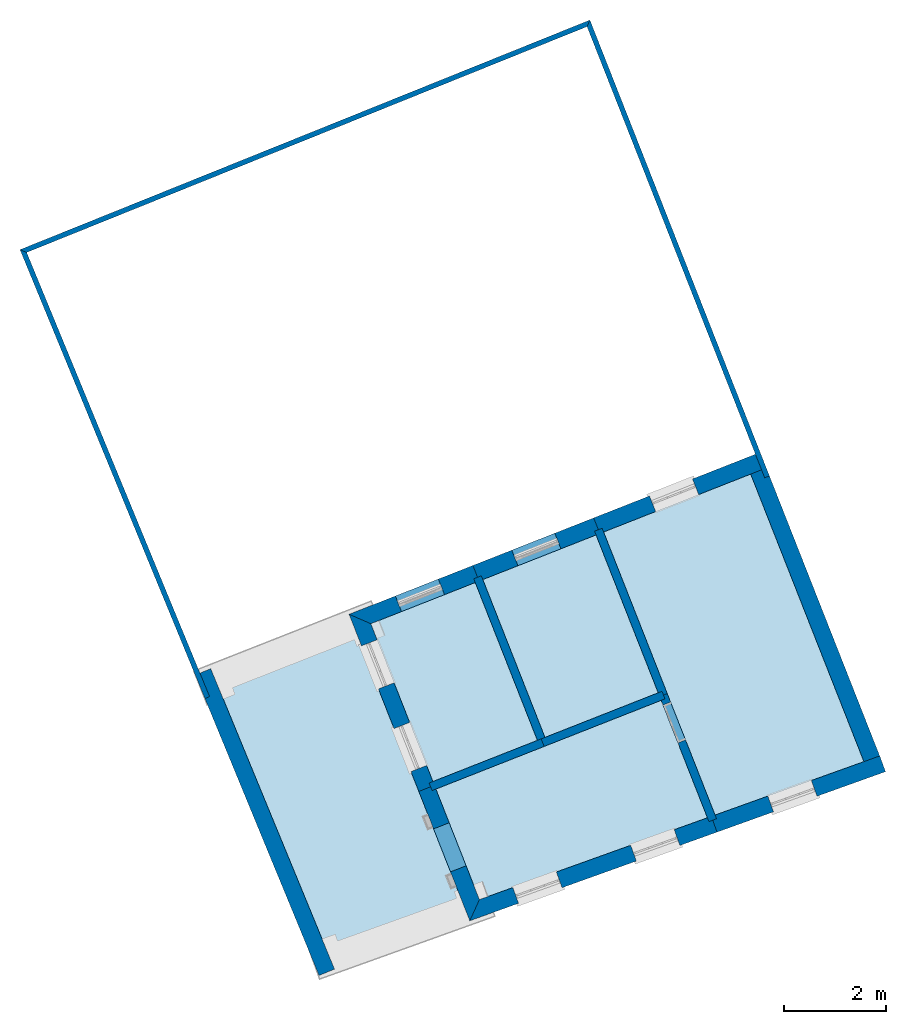
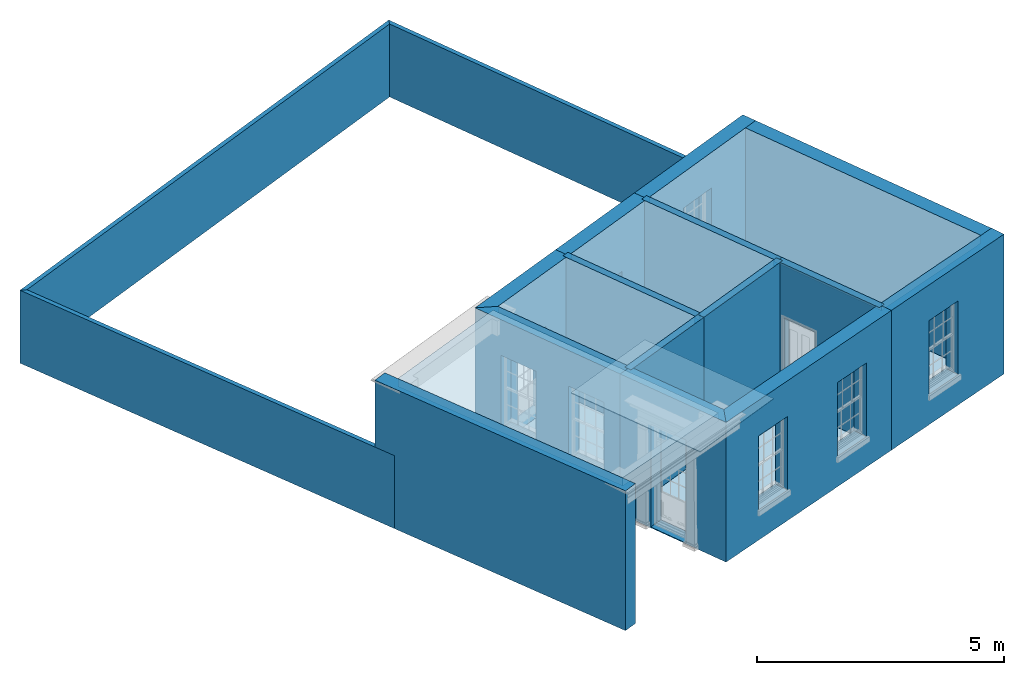
# One storey, part 1 of 8: 17 walls, 8 slabs, 10 openings.
"""IFC2X3 building model written with IfcOpenShell, lengths in metres."""

from ifc_helpers import new_model, si_unit, frame, origin, place, context, subcontext, project, spatial, polyline, outline, extrude, material, layer, layer_set, layer_usage, element, save


model = new_model("IFC2X3")

# Units and contexts
model_context = context("Model", 3, world=origin())
body_context = subcontext(model_context, "Body", "Model", "MODEL_VIEW")
ifc_project = project(units=[si_unit("PLANEANGLEUNIT", "RADIAN"), si_unit("MASSUNIT", "GRAM", prefix="KILO"), si_unit("FORCEUNIT", "NEWTON", prefix="KILO"), si_unit("LENGTHUNIT", "METRE")], contexts=[model_context])

# Site, building, storey
site_placement = place(None, origin())
site = spatial("IfcSite", under=ifc_project, at=site_placement, CompositionType="ELEMENT")
building_placement = place(None, origin())
building = spatial("IfcBuilding", under=site, at=building_placement, Name="Building plot-4", CompositionType="ELEMENT")
storey_placement = place(None, frame((0.0, 0.0, 3.0)))
storey = spatial("IfcBuildingStorey", under=building, at=storey_placement, Name="Floor 0", CompositionType="ELEMENT", Elevation=3.0)

# Slabs
slab_1_placement = place(storey_placement, frame((0.0, 0.0, 3.25)))
element("IfcSlab", 1, at=slab_1_placement, inside=storey, Name="Slab", ObjectType="Slab", PredefinedType="FLOOR", context=body_context, shape_type="SweptSolid", body=[
    extrude(outline(polyline([(47.3779728153786, 51.938533144609), (44.502052775966, 50.8059380590818), (46.6888976082681, 45.4977503358858), (49.5151493068038, 46.5117493116291), (47.3779728153786, 51.938533144609)])), origin(), (0.0, 0.0, 1.0), 0.2),
])
slab_2_placement = place(storey_placement, frame((0.0, 0.0, 3.25)))
element("IfcSlab", 2, at=slab_2_placement, inside=storey, Name="Slab", ObjectType="Slab", PredefinedType="FLOOR", context=body_context, shape_type="SweptSolid", body=[
    extrude(outline(polyline([(50.9563121382697, 49.7590058579402), (53.185811513538, 50.6370275000616), (51.9622563685918, 53.743916100977), (49.7327569933235, 52.8658944588556), (50.9563121382697, 49.7590058579402)])), origin(), (0.0, 0.0, 1.0), 0.2),
])
slab_3_placement = place(storey_placement, frame((0.0, 0.0, 3.25)))
element("IfcSlab", 3, at=slab_3_placement, inside=storey, Name="Slab", ObjectType="Slab", PredefinedType="FLOOR", context=body_context, shape_type="SweptSolid", body=[
    extrude(outline(polyline([(48.7503993592311, 48.8902730912423), (50.8074407393634, 49.7003773103915), (49.5838855944172, 52.8072659113069), (47.5268442142849, 51.9971616921577), (48.7503993592311, 48.8902730912423)])), origin(), (0.0, 0.0, 1.0), 0.2),
])
slab_4_placement = place(storey_placement, frame((0.0, 0.0, 3.25)))
element("IfcSlab", 4, at=slab_4_placement, inside=storey, Name="Slab", ObjectType="Slab", PredefinedType="FLOOR", context=body_context, shape_type="SweptSolid", body=[
    extrude(outline(polyline([(52.1111277674981, 53.8025446485257), (54.3055353434882, 48.2304378973377), (57.2362120204166, 49.2819023334951), (55.0067914405798, 54.9429151736193), (52.1111277674981, 53.8025446485257)])), origin(), (0.0, 0.0, 1.0), 0.2),
])
slab_5_placement = place(storey_placement, origin())
element("IfcSlab", 5, at=slab_5_placement, inside=storey, Name="Slab", ObjectType="Slab", PredefinedType="FLOOR", context=body_context, shape_type="SweptSolid", body=[
    extrude(outline(polyline([(52.1111277674981, 53.8025446485257), (54.3055353434882, 48.2304378973377), (57.2362120204166, 49.2819023334951), (55.0067914405798, 54.9429151736193), (52.1111277674981, 53.8025446485257)])), origin(), (0.0, 0.0, 1.0), 0.02),
])
slab_6_placement = place(storey_placement, origin())
element("IfcSlab", 6, at=slab_6_placement, inside=storey, Name="Slab", ObjectType="Slab", PredefinedType="FLOOR", context=body_context, shape_type="SweptSolid", body=[
    extrude(outline(polyline([(50.9563121382697, 49.7590058579402), (53.185811513538, 50.6370275000616), (51.9622563685918, 53.743916100977), (49.7327569933235, 52.8658944588556), (50.9563121382697, 49.7590058579402)])), origin(), (0.0, 0.0, 1.0), 0.02),
])
slab_7_placement = place(storey_placement, origin())
element("IfcSlab", 7, at=slab_7_placement, inside=storey, Name="Slab", ObjectType="Slab", PredefinedType="FLOOR", context=body_context, shape_type="SweptSolid", body=[
    extrude(outline(polyline([(54.1548638616126, 48.176380175453), (53.2444400610867, 50.4881561011553), (48.8090279067798, 48.741401692336), (49.6658207886794, 46.5658070335138), (54.1548638616126, 48.176380175453)])), origin(), (0.0, 0.0, 1.0), 0.02),
])
slab_8_placement = place(storey_placement, origin())
element("IfcSlab", 8, at=slab_8_placement, inside=storey, Name="Slab", ObjectType="Slab", PredefinedType="FLOOR", context=body_context, shape_type="SweptSolid", body=[
    extrude(outline(polyline([(48.7503993592311, 48.8902730912423), (50.8074407393634, 49.7003773103915), (49.5838855944172, 52.8072659113069), (47.5268442142849, 51.9971616921577), (48.7503993592311, 48.8902730912423)])), origin(), (0.0, 0.0, 1.0), 0.02),
])

# Wall, opening
ifc_material_1 = material(Name="Masonry")
ifc_layer_1 = layer(ifc_material_1, 0.33, ventilated=False)
ifc_layer_set_1 = layer_set([ifc_layer_1], Name="My Wall")
ifc_layer_usage_1 = layer_usage(ifc_layer_set_1, "AXIS2", "NEGATIVE", 0.08)
wall_1_placement = place(storey_placement, origin())
wall_1 = element("IfcWallStandardCase", 9, at=wall_1_placement, inside=storey, material=ifc_layer_usage_1, Name="exterior", context=body_context, shape_type="SweptSolid", body=[
    extrude(outline(polyline([(55.3138387008242, 55.0638365529384), (55.192917321505, 55.3708838131828), (51.9157706887258, 54.0802776349957), (52.0366920680449, 53.7732303747513), (55.3138387008242, 55.0638365529384)])), origin(), (0.0, 0.0, 1.0), 3.45),
])
opening_1_placement = place(storey_placement, frame((0.0, 0.0, 0.75)))
element("IfcOpeningElement", 10, at=opening_1_placement, cuts=wall_1, Name="Opening", ObjectType="Opening", context=body_context, shape_type="SweptSolid", body=[
    extrude(outline(polyline([(53.8613912653598, 54.8465021034084), (53.0146851840799, 54.5130522392253), (53.1356065633991, 54.2060049789809), (53.9823126446789, 54.539454843164), (53.8613912653598, 54.8465021034084)])), origin(), (0.0, 0.0, 1.0), 1.82),
])

wall_2_placement = place(storey_placement, origin())
wall_2 = element("IfcWallStandardCase", 11, at=wall_2_placement, inside=storey, material=ifc_layer_usage_1, Name="exterior", context=body_context, shape_type="SweptSolid", body=[
    extrude(outline(polyline([(52.0366920680449, 53.7732303747513), (51.9157706887258, 54.0802776349957), (49.5373999145512, 53.1436274453256), (49.6583212938703, 52.8365801850812), (52.0366920680449, 53.7732303747513)])), origin(), (0.0, 0.0, 1.0), 3.45),
])
opening_2_placement = place(storey_placement, frame((0.0, 0.0, 0.02)))
element("IfcOpeningElement", 12, at=opening_2_placement, cuts=wall_2, Name="Opening", ObjectType="Opening", context=body_context, shape_type="SweptSolid", body=[
    extrude(outline(polyline([(51.1499383422784, 53.7786774722522), (50.3032322609986, 53.4452276080691), (50.4241536403177, 53.1381803478247), (51.2708597215976, 53.4716302120078), (51.1499383422784, 53.7786774722522)])), origin(), (0.0, 0.0, 1.0), 2.08),
])

wall_3_placement = place(storey_placement, origin())
wall_3 = element("IfcWallStandardCase", 13, at=wall_3_placement, inside=storey, material=ifc_layer_usage_1, Name="exterior", context=body_context, shape_type="SweptSolid", body=[
    extrude(outline(polyline([(49.6583212938703, 52.8365801850812), (49.5373999145512, 53.1436274453256), (47.0988755747214, 52.1832875730829), (47.5268442142849, 51.9971616921577), (49.6583212938703, 52.8365801850812)])), origin(), (0.0, 0.0, 1.0), 3.45),
])
opening_3_placement = place(storey_placement, frame((0.0, 0.0, 0.02)))
element("IfcOpeningElement", 14, at=opening_3_placement, cuts=wall_3, Name="Opening", ObjectType="Opening", context=body_context, shape_type="SweptSolid", body=[
    extrude(outline(polyline([(48.8577965656718, 52.8759859940682), (48.011090484392, 52.5425361298851), (48.1320118637111, 52.2354888696407), (48.978717944991, 52.5689387338238), (48.8577965656718, 52.8759859940682)])), origin(), (0.0, 0.0, 1.0), 2.08),
])

# Wall, openings
wall_4_placement = place(storey_placement, origin())
wall_4 = element("IfcWallStandardCase", 15, at=wall_4_placement, inside=storey, material=ifc_layer_usage_1, Name="exterior", context=body_context, shape_type="SweptSolid", body=[
    extrude(outline(polyline([(47.5268442142849, 51.9971616921577), (47.0988755747214, 52.1832875730829), (48.4726663727611, 48.69491601247), (48.7797136330055, 48.8158373917891), (47.5268442142849, 51.9971616921577)])), origin(), (0.0, 0.0, 1.0), 3.45),
])
opening_4_placement = place(storey_placement, frame((0.0, 0.0, 0.75)))
element("IfcOpeningElement", 16, at=opening_4_placement, cuts=wall_4, Name="Opening", ObjectType="Opening", context=body_context, shape_type="SweptSolid", body=[
    extrude(outline(polyline([(47.3443036712984, 51.5600890529762), (47.6777535354815, 50.7133829716963), (47.9848007957258, 50.8343043510155), (47.6513509315428, 51.6810104322953), (47.3443036712984, 51.5600890529762)])), origin(), (0.0, 0.0, 1.0), 1.82),
])
opening_5_placement = place(storey_placement, frame((0.0, 0.0, 0.75)))
element("IfcOpeningElement", 17, at=opening_5_placement, cuts=wall_4, Name="Opening", ObjectType="Opening", context=body_context, shape_type="SweptSolid", body=[
    extrude(outline(polyline([(47.9853955175459, 49.9322090530653), (48.3188453817289, 49.0855029717855), (48.6258926419733, 49.2064243511046), (48.2924427777902, 50.0531304323845), (47.9853955175459, 49.9322090530653)])), origin(), (0.0, 0.0, 1.0), 1.82),
])

# Wall, opening
wall_5_placement = place(storey_placement, origin())
wall_5 = element("IfcWallStandardCase", 18, at=wall_5_placement, inside=storey, material=ifc_layer_usage_1, Name="exterior", context=body_context, shape_type="SweptSolid", body=[
    extrude(outline(polyline([(48.7797136330055, 48.8158373917891), (48.4726663727611, 48.69491601247), (49.476039218613, 46.1471210314907), (49.6658207886794, 46.5658070335138), (48.7797136330055, 48.8158373917891)])), origin(), (0.0, 0.0, 1.0), 3.45),
])
opening_6_placement = place(storey_placement, frame((0.0, 0.0, 0.02)))
element("IfcOpeningElement", 19, at=opening_6_placement, cuts=wall_5, Name="Opening", ObjectType="Opening", context=body_context, shape_type="SweptSolid", body=[
    extrude(outline(polyline([(48.7632090415584, 47.9571611924324), (49.0966589057415, 47.1104551111525), (49.4037061659859, 47.2313764904717), (49.0702563018028, 48.0780825717515), (48.7632090415584, 47.9571611924324)])), origin(), (0.0, 0.0, 1.0), 2.545),
])

# Wall, openings
wall_6_placement = place(storey_placement, origin())
wall_6 = element("IfcWallStandardCase", 20, at=wall_6_placement, inside=storey, material=ifc_layer_usage_1, Name="exterior", context=body_context, shape_type="SweptSolid", body=[
    extrude(outline(polyline([(49.6658207886794, 46.5658070335138), (49.476039218613, 46.1471210314907), (54.3439530966588, 47.8936249571326), (54.2325115600524, 48.2042385175559), (49.6658207886794, 46.5658070335138)])), origin(), (0.0, 0.0, 1.0), 3.45),
])
opening_7_placement = place(storey_placement, frame((0.0, 0.0, 0.75)))
element("IfcOpeningElement", 21, at=opening_7_placement, cuts=wall_6, Name="Opening", ObjectType="Opening", context=body_context, shape_type="SweptSolid", body=[
    extrude(outline(polyline([(50.4358969684534, 46.4914975693984), (51.2924373926509, 46.7988060491311), (51.1809958560445, 47.1094196095543), (50.3244554318471, 46.8021111298216), (50.4358969684534, 46.4914975693984)])), origin(), (0.0, 0.0, 1.0), 1.82),
])
opening_8_placement = place(storey_placement, frame((0.0, 0.0, 0.75)))
element("IfcOpeningElement", 22, at=opening_8_placement, cuts=wall_6, Name="Opening", ObjectType="Opening", context=body_context, shape_type="SweptSolid", body=[
    extrude(outline(polyline([(52.7557542458578, 47.3238130013103), (53.6122946700553, 47.631121481043), (53.5008531334489, 47.9417350414663), (52.6443127092515, 47.6344265617336), (52.7557542458578, 47.3238130013103)])), origin(), (0.0, 0.0, 1.0), 1.82),
])

# Wall, opening
wall_7_placement = place(storey_placement, origin())
wall_7 = element("IfcWallStandardCase", 23, at=wall_7_placement, inside=storey, material=ifc_layer_usage_1, Name="exterior", context=body_context, shape_type="SweptSolid", body=[
    extrude(outline(polyline([(54.2325115600524, 48.2042385175559), (54.3439530966588, 47.8936249571326), (57.6606145588137, 49.0835725216947), (57.5491730222074, 49.394186082118), (54.2325115600524, 48.2042385175559)])), origin(), (0.0, 0.0, 1.0), 3.45),
])
opening_9_placement = place(storey_placement, frame((0.0, 0.0, 0.75)))
element("IfcOpeningElement", 24, at=opening_9_placement, cuts=wall_7, Name="Opening", ObjectType="Opening", context=body_context, shape_type="SweptSolid", body=[
    extrude(outline(polyline([(55.456356963962, 48.2927317962874), (56.3128973881595, 48.60004027602), (56.2014558515532, 48.9106538364433), (55.3449154273557, 48.6033453567106), (55.456356963962, 48.2927317962874)])), origin(), (0.0, 0.0, 1.0), 1.82),
])

# Walls
wall_8_placement = place(storey_placement, origin())
element("IfcWallStandardCase", 25, at=wall_8_placement, inside=storey, material=ifc_layer_usage_1, Name="party", context=body_context, shape_type="SweptSolid", body=[
    extrude(outline(polyline([(57.2664401494896, 49.2051461447514), (57.573487409734, 49.3260675240705), (55.2845244270499, 55.1382722523916), (54.9774771668055, 55.0173508730725), (57.2664401494896, 49.2051461447514)])), origin(), (0.0, 0.0, 1.0), 3.45),
])
ifc_material_2 = material(Name="Masonry")
ifc_layer_2 = layer(ifc_material_2, 0.16, ventilated=False)
ifc_layer_set_2 = layer_set([ifc_layer_2], Name="My Wall")
ifc_layer_usage_2 = layer_usage(ifc_layer_set_2, "AXIS2", "NEGATIVE", 0.08)
wall_9_placement = place(storey_placement, origin())
element("IfcWallStandardCase", 26, at=wall_9_placement, inside=storey, material=ifc_layer_usage_2, Name="interior", context=body_context, shape_type="SweptSolid", body=[
    extrude(outline(polyline([(50.9405049863652, 49.5808201852595), (50.8818764388166, 49.7296915841659), (48.675963659778, 48.860958817468), (48.7345922073266, 48.7120874185616), (50.9405049863652, 49.5808201852595)])), origin(), (0.0, 0.0, 1.0), 3.45),
])

# Wall, opening
wall_10_placement = place(storey_placement, origin())
wall_10 = element("IfcWallStandardCase", 27, at=wall_10_placement, inside=storey, material=ifc_layer_usage_2, Name="interior", context=body_context, shape_type="SweptSolid", body=[
    extrude(outline(polyline([(54.1850919906856, 48.0996239867093), (54.333963389592, 48.1582525342579), (53.3639971862187, 50.6212203481571), (53.2151257873123, 50.5625918006085), (54.1850919906856, 48.0996239867093)])), origin(), (0.0, 0.0, 1.0), 3.45),
])
opening_10_placement = place(storey_placement, frame((0.0, 0.0, 0.02)))
element("IfcOpeningElement", 28, at=opening_10_placement, cuts=wall_10, Name="Opening", ObjectType="Opening", context=body_context, shape_type="SweptSolid", body=[
    extrude(outline(polyline([(53.7230970399543, 49.7093830298558), (53.4299543022109, 50.4537400243875), (53.2810829033046, 50.3951114768388), (53.574225641048, 49.6507544823071), (53.7230970399543, 49.7093830298558)])), origin(), (0.0, 0.0, 1.0), 2.1),
])

# Walls
wall_11_placement = place(storey_placement, origin())
element("IfcWallStandardCase", 29, at=wall_11_placement, inside=storey, material=ifc_layer_usage_2, Name="interior", context=body_context, shape_type="SweptSolid", body=[
    extrude(outline(polyline([(53.3188757605398, 50.5174703749296), (53.2602472129912, 50.666341773836), (50.8818764388166, 49.7296915841659), (50.9405049863652, 49.5808201852595), (53.3188757605398, 50.5174703749296)])), origin(), (0.0, 0.0, 1.0), 3.45),
])
wall_12_placement = place(storey_placement, origin())
element("IfcWallStandardCase", 30, at=wall_12_placement, inside=storey, material=ifc_layer_usage_2, Name="interior", context=body_context, shape_type="SweptSolid", body=[
    extrude(outline(polyline([(53.2151257873123, 50.5625918006085), (53.3639971862187, 50.6212203481571), (52.0818134937238, 53.8769803479788), (51.9329420948174, 53.8183518004302), (53.2151257873123, 50.5625918006085)])), origin(), (0.0, 0.0, 1.0), 3.45),
])
wall_13_placement = place(storey_placement, origin())
element("IfcWallStandardCase", 31, at=wall_13_placement, inside=storey, material=ifc_layer_usage_2, Name="interior", context=body_context, shape_type="SweptSolid", body=[
    extrude(outline(polyline([(50.8367550131377, 49.6259416109384), (50.9856264120441, 49.684570158487), (49.7034427195492, 52.9403301583087), (49.5545713206428, 52.8817016107601), (50.8367550131377, 49.6259416109384)])), origin(), (0.0, 0.0, 1.0), 3.45),
])
wall_14_placement = place(storey_placement, origin())
element("IfcWallStandardCase", 32, at=wall_14_placement, inside=storey, material=ifc_layer_usage_1, Name="party", context=body_context, shape_type="SweptSolid", body=[
    extrude(outline(polyline([(44.375870523747, 51.1122236593314), (44.0707494318127, 50.9865211563458), (46.5080993932409, 45.0702755447329), (46.8132204851752, 45.1959780477184), (44.375870523747, 51.1122236593314)])), origin(), (0.0, 0.0, 1.0), 3.45),
])
ifc_material_3 = material(Name="Masonry")
ifc_layer_3 = layer(ifc_material_3, 0.1, ventilated=False)
ifc_layer_set_3 = layer_set([ifc_layer_3], Name="My Wall")
ifc_layer_usage_3 = layer_usage(ifc_layer_set_3, "AXIS2", "NEGATIVE", -0.15)
wall_15_placement = place(storey_placement, origin())
element("IfcWallStandardCase", 33, at=wall_15_placement, inside=storey, material=ifc_layer_usage_3, Name="fence", context=body_context, shape_type="SweptSolid", body=[
    extrude(outline(polyline([(55.2830869082782, 54.8690178493825), (55.3761315325947, 54.9056606916004), (51.8406330762671, 63.8831063734625), (51.7845235700152, 63.7526767511701), (55.2830869082782, 54.8690178493825)])), origin(), (0.0, 0.0, 1.0), 1.8),
])
wall_16_placement = place(storey_placement, origin())
element("IfcWallStandardCase", 34, at=wall_16_placement, inside=storey, material=ifc_layer_usage_3, Name="fence", context=body_context, shape_type="SweptSolid", body=[
    extrude(outline(polyline([(51.7845235700152, 63.7526767511701), (51.8406330762671, 63.8831063734625), (40.620606901068, 59.3611456173306), (40.7514530005142, 59.3060639397671), (51.7845235700152, 63.7526767511701)])), origin(), (0.0, 0.0, 1.0), 1.8),
])
wall_17_placement = place(storey_placement, origin())
element("IfcWallStandardCase", 35, at=wall_17_placement, inside=storey, material=ifc_layer_usage_3, Name="fence", context=body_context, shape_type="SweptSolid", body=[
    extrude(outline(polyline([(40.7514530005142, 59.3060639397671), (40.620606901068, 59.3611456173306), (44.2612077696696, 50.5242164715969), (44.3536687066194, 50.5623081391683), (40.7514530005142, 59.3060639397671)])), origin(), (0.0, 0.0, 1.0), 1.8),
])

save(model, "model.ifc")
